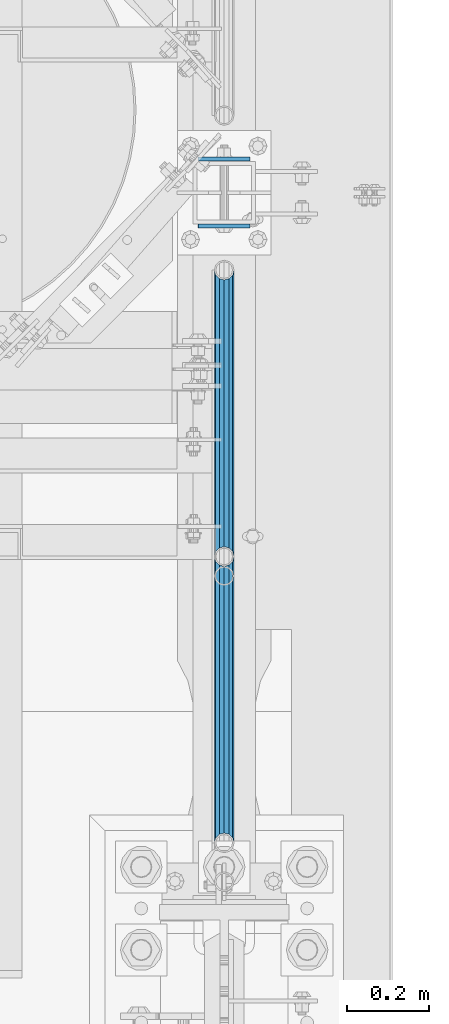
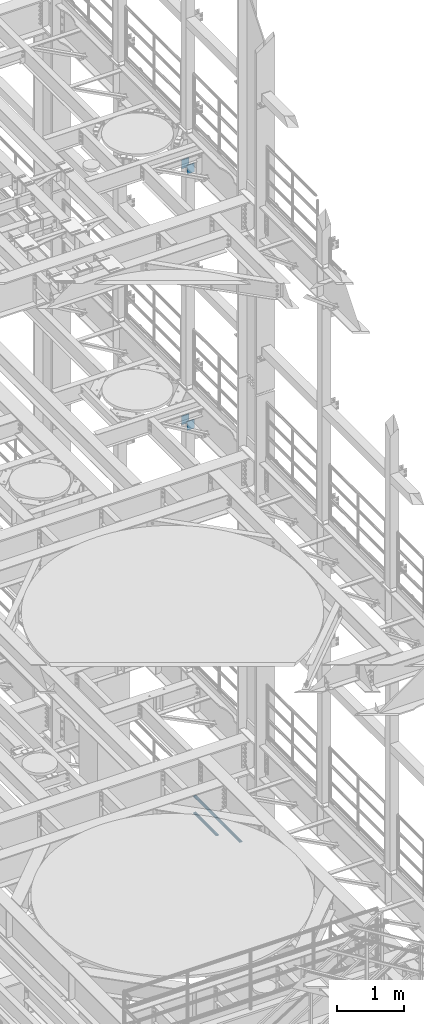
# One storey, part 1277 of 1876: 7 beams, 3 elements without a shape of their own.
"""IFC2X3 building model written with IfcOpenShell, lengths in millimetres."""

from ifc_helpers import new_model, si_unit, frame, origin_with_axes, place, context, subcontext, project, spatial, faceted_brep, material, type_object, element, aggregate, save


model = new_model("IFC2X3")

# Units and contexts
model_context = context("Model", 3, precision=1e-05, world=origin_with_axes())
body_context = subcontext(model_context, "Body", "Model", "MODEL_VIEW")
ifc_project = project(units=[si_unit("LENGTHUNIT", "METRE", prefix="MILLI"), si_unit("AREAUNIT", "SQUARE_METRE"), si_unit("VOLUMEUNIT", "CUBIC_METRE"), si_unit("MASSUNIT", "GRAM", prefix="KILO"), si_unit("TIMEUNIT", "SECOND"), si_unit("PLANEANGLEUNIT", "RADIAN"), si_unit("SOLIDANGLEUNIT", "STERADIAN"), si_unit("THERMODYNAMICTEMPERATUREUNIT", "DEGREE_CELSIUS"), si_unit("LUMINOUSINTENSITYUNIT", "LUMEN")], contexts=[model_context])

# Site, building, storey
site_placement = place(None, origin_with_axes())
site = spatial("IfcSite", under=ifc_project, at=site_placement, CompositionType="ELEMENT")
building_placement = place(site_placement, origin_with_axes())
building = spatial("IfcBuilding", under=site, at=building_placement, Name="Undefined", CompositionType="ELEMENT")
storey_placement = place(building_placement, origin_with_axes())
storey = spatial("IfcBuildingStorey", under=building, at=storey_placement, Name="Undefined", CompositionType="ELEMENT", Elevation=0.0)

# Assembly, beams
assembly_1_placement = place(storey_placement, origin_with_axes())
assembly_1 = element("IfcElementAssembly", 1, at=assembly_1_placement, inside=storey, Name="RAIL", AssemblyPlace="NOTDEFINED", PredefinedType="RIGID_FRAME")
ifc_material_1 = material()
beam_type_1 = type_object("IfcBeamType", Name="PIPE1-1/2SCH40", PredefinedType="NOTDEFINED")
beam_1_placement = place(assembly_1_placement, frame((7620.0, 2665.4125, 5597.525), z_axis=(0.0, 0.0, -1.0), x_axis=(0.0, 1.0, 0.0)))
beam_1 = element("IfcBeam", 2, at=beam_1_placement, type_object=beam_type_1, material=ifc_material_1, Name="RAIL", ObjectType="PIPE1-1/2SCH40", context=body_context, shape_type="Brep", body=[
    faceted_brep([(0.0, 24.1299999999992, 0.0), (12.0650000000064, 20.8971929933177, -12.0649999999987), (12.0650000000064, 20.8971929933177, 12.0649999999987), (12.0650000000064, -20.8971929933177, 12.0649999999987), (12.0650000000064, -20.8971929933177, -12.0649999999987), (0.0, -24.1299999999992, 0.0), (20.8971929933249, -12.0650000000005, 20.8971929933177), (20.8971929933249, -12.0650000000005, 15.8661214311796), (15.2545715621445, -17.7076214311801, 10.2235000000001), (12.5151929933249, -20.4470000000001, 0.0), (15.2545715621445, -17.7076214311801, -10.2235000000001), (20.8971929933249, -12.0650000000005, -15.8661214311796), (20.8971929933249, -12.0650000000005, -20.8971929933177), (24.1300000000063, 0.0, -20.4470000000001), (24.1300000000063, 0.0, -24.130000000001), (21.3906214311868, -10.2235000000001, -17.7076214311819), (21.3906214311868, 10.2235000000001, -17.7076214311819), (20.8971929933249, 12.0650000000005, -15.8661214311796), (20.8971929933249, 12.0650000000005, -20.8971929933177), (15.2545715621445, 17.7076214311801, -10.2235000000001), (12.5151929933249, 20.4470000000001, 0.0), (15.2545715621445, 17.7076214311801, 10.2235000000001), (20.8971929933249, 12.0650000000005, 15.8661214311796), (20.8971929933249, 12.0650000000005, 20.8971929933177), (21.3906214311868, 10.2235000000001, 17.7076214311819), (24.1300000000064, 0.0, 20.4470000000001), (24.1300000000064, 0.0, 24.130000000001), (21.3906214311868, -10.2235000000001, 17.7076214311819), (701.3575, 24.1300000000001, 0.0), (689.2925, 20.8971929933186, -12.0649999999996), (680.460307006681, 12.0649999999996, -20.8971929933186), (701.3575, -24.1299999999919, 0.0), (689.2925, -20.8971929933186, -12.0649999999996), (689.2925, -20.8971929933186, 12.0649999999996), (680.460307006681, -12.0649999999996, 20.8971929933186), (680.460307006681, -12.0649999999996, -20.8971929933186), (677.2275, 0.0, -24.1300000000001), (679.966878568817, 10.2235000000001, -17.7076214311801), (677.2275, 0.0, -20.4470000000001), (680.460307006681, 12.0650000000078, -15.8661214311724), (680.460307006681, -12.0649999999914, -15.8661214311887), (679.966878568822, -10.2235000000001, -17.7076214311801), (686.10292843787, -17.7076214311801, -10.2235000000001), (688.842307006689, -20.4470000000001, 0.0), (686.10292843787, -17.7076214311801, 10.2235000000001), (680.460307006681, -12.0649999999914, 15.8661214311887), (679.966878568822, -10.2235000000001, 17.7076214311801), (677.2275, 0.0, 20.4470000000001), (677.2275, 0.0, 24.1300000000001), (680.460307006681, 12.0649999999996, 20.8971929933186), (689.2925, 20.8971929933186, 12.0649999999996), (680.460307006681, 12.0650000000078, 15.8661214311724), (686.102928437854, 17.7076214311801, 10.2235000000001), (688.842307006673, 20.4470000000001, 0.0), (686.102928437854, 17.7076214311801, -10.2235000000001), (679.966878568817, 10.2235000000001, 17.7076214311801)], [[[0, 1, 2]], [[3, 4, 5]], [[6, 7, 8, 9, 10, 11, 12, 4, 3]], [[13, 14, 12, 11, 15]], [[16, 17, 18, 14, 13]], [[2, 1, 18, 17, 19, 20, 21, 22, 23]], [[23, 22, 24, 25, 26]], [[26, 25, 27, 7, 6]], [[1, 0, 28, 29]], [[18, 1, 29, 30]], [[31, 32, 33]], [[6, 3, 33, 34]], [[3, 5, 31, 33]], [[5, 4, 32, 31]], [[4, 12, 35, 32]], [[12, 14, 36, 35]], [[14, 18, 30, 36]], [[37, 38, 36, 30, 39]], [[40, 35, 36, 38, 41]], [[33, 32, 35, 40, 42, 43, 44, 45, 34]], [[34, 45, 46, 47, 48]], [[26, 6, 34, 48]], [[2, 23, 49, 50]], [[23, 26, 48, 49]], [[0, 2, 50, 28]], [[28, 50, 29]], [[49, 51, 52, 53, 54, 39, 30, 29, 50]], [[48, 47, 55, 51, 49]], [[25, 24, 55, 47]], [[55, 24, 22, 21, 52, 51]], [[21, 20, 53, 52]], [[20, 19, 54, 53]], [[19, 17, 16, 37, 39, 54]], [[16, 13, 38, 37]], [[13, 15, 41, 38]], [[41, 15, 11, 10, 42, 40]], [[10, 9, 43, 42]], [[9, 8, 44, 43]], [[8, 7, 27, 46, 45, 44]], [[27, 25, 47, 46]]]),
])
beam_2_placement = place(assembly_1_placement, frame((7620.0, 1964.055, 5902.325), z_axis=(0.0, 0.0, -1.0), x_axis=(0.0, 1.0, 0.0)))
beam_2 = element("IfcBeam", 3, at=beam_2_placement, type_object=beam_type_1, material=ifc_material_1, Name="RAIL", ObjectType="PIPE1-1/2SCH40", context=body_context, shape_type="Brep", body=[
    faceted_brep([(0.0, 24.1299999999992, 0.0), (12.0650000000064, 20.8971929933177, -12.0649999999987), (12.0650000000064, 20.8971929933177, 12.0649999999987), (12.0650000000064, -20.8971929933177, 12.0649999999987), (12.0650000000064, -20.8971929933177, -12.0649999999987), (0.0, -24.1299999999992, 0.0), (20.8971929933249, -12.0650000000005, 20.8971929933177), (20.8971929933249, -12.0650000000005, 15.8661214311796), (15.2545715621445, -17.7076214311801, 10.2235000000001), (12.5151929933249, -20.4470000000001, 0.0), (15.2545715621445, -17.7076214311801, -10.2235000000001), (20.8971929933249, -12.0650000000005, -15.8661214311796), (20.8971929933249, -12.0650000000005, -20.8971929933177), (24.1300000000063, 0.0, -20.4470000000001), (24.1300000000063, 0.0, -24.130000000001), (21.3906214311868, -10.2235000000001, -17.7076214311819), (21.3906214311868, 10.2235000000001, -17.7076214311819), (20.8971929933249, 12.0650000000005, -15.8661214311796), (20.8971929933249, 12.0650000000005, -20.8971929933177), (15.2545715621445, 17.7076214311801, -10.2235000000001), (12.5151929933249, 20.4470000000001, 0.0), (15.2545715621445, 17.7076214311801, 10.2235000000001), (20.8971929933249, 12.0650000000005, 15.8661214311796), (20.8971929933249, 12.0650000000005, 20.8971929933177), (21.3906214311868, 10.2235000000001, 17.7076214311819), (24.1300000000064, 0.0, 20.4470000000001), (24.1300000000064, 0.0, 24.130000000001), (21.3906214311868, -10.2235000000001, 17.7076214311819), (701.3575, 24.1300000000001, 0.0), (689.2925, 20.8971929933186, -12.0649999999996), (680.460307006681, 12.0649999999996, -20.8971929933186), (701.3575, -24.1299999999919, 0.0), (689.2925, -20.8971929933186, -12.0649999999996), (689.2925, -20.8971929933186, 12.0649999999996), (680.460307006681, -12.0649999999996, 20.8971929933186), (680.460307006681, -12.0649999999996, -20.8971929933186), (677.2275, 0.0, -24.1300000000001), (679.966878568817, 10.2235000000001, -17.7076214311801), (677.2275, 0.0, -20.4470000000001), (680.460307006681, 12.0650000000078, -15.8661214311724), (680.460307006681, -12.0649999999914, -15.8661214311887), (679.966878568822, -10.2235000000001, -17.7076214311801), (686.10292843787, -17.7076214311801, -10.2235000000001), (688.842307006689, -20.4470000000001, 0.0), (686.10292843787, -17.7076214311801, 10.2235000000001), (680.460307006681, -12.0649999999914, 15.8661214311887), (679.966878568822, -10.2235000000001, 17.7076214311801), (677.2275, 0.0, 20.4470000000001), (677.2275, 0.0, 24.1300000000001), (680.460307006681, 12.0649999999996, 20.8971929933186), (689.2925, 20.8971929933186, 12.0649999999996), (680.460307006681, 12.0650000000078, 15.8661214311724), (686.102928437854, 17.7076214311801, 10.2235000000001), (688.842307006673, 20.4470000000001, 0.0), (686.102928437854, 17.7076214311801, -10.2235000000001), (679.966878568817, 10.2235000000001, 17.7076214311801)], [[[0, 1, 2]], [[3, 4, 5]], [[6, 7, 8, 9, 10, 11, 12, 4, 3]], [[13, 14, 12, 11, 15]], [[16, 17, 18, 14, 13]], [[2, 1, 18, 17, 19, 20, 21, 22, 23]], [[23, 22, 24, 25, 26]], [[26, 25, 27, 7, 6]], [[1, 0, 28, 29]], [[18, 1, 29, 30]], [[31, 32, 33]], [[6, 3, 33, 34]], [[3, 5, 31, 33]], [[5, 4, 32, 31]], [[4, 12, 35, 32]], [[12, 14, 36, 35]], [[14, 18, 30, 36]], [[37, 38, 36, 30, 39]], [[40, 35, 36, 38, 41]], [[33, 32, 35, 40, 42, 43, 44, 45, 34]], [[34, 45, 46, 47, 48]], [[26, 6, 34, 48]], [[2, 23, 49, 50]], [[23, 26, 48, 49]], [[0, 2, 50, 28]], [[28, 50, 29]], [[49, 51, 52, 53, 54, 39, 30, 29, 50]], [[48, 47, 55, 51, 49]], [[25, 24, 55, 47]], [[55, 24, 22, 21, 52, 51]], [[21, 20, 53, 52]], [[20, 19, 54, 53]], [[19, 17, 16, 37, 39, 54]], [[16, 13, 38, 37]], [[13, 15, 41, 38]], [[41, 15, 11, 10, 42, 40]], [[10, 9, 43, 42]], [[9, 8, 44, 43]], [[8, 7, 27, 46, 45, 44]], [[27, 25, 47, 46]]]),
])
beam_3_placement = place(assembly_1_placement, frame((7620.0, 2665.4125, 5902.325), z_axis=(0.0, 0.0, -1.0), x_axis=(0.0, 1.0, 0.0)))
beam_3 = element("IfcBeam", 4, at=beam_3_placement, type_object=beam_type_1, material=ifc_material_1, Name="RAIL", ObjectType="PIPE1-1/2SCH40", context=body_context, shape_type="Brep", body=[
    faceted_brep([(0.0, 24.1299999999992, 0.0), (12.0650000000064, 20.8971929933177, -12.0649999999987), (12.0650000000064, 20.8971929933177, 12.0649999999987), (12.0650000000064, -20.8971929933177, 12.0649999999987), (12.0650000000064, -20.8971929933177, -12.0649999999987), (0.0, -24.1299999999992, 0.0), (20.8971929933249, -12.0650000000005, 20.8971929933177), (20.8971929933249, -12.0650000000005, 15.8661214311796), (15.2545715621445, -17.7076214311801, 10.2235000000001), (12.5151929933249, -20.4470000000001, 0.0), (15.2545715621445, -17.7076214311801, -10.2235000000001), (20.8971929933249, -12.0650000000005, -15.8661214311796), (20.8971929933249, -12.0650000000005, -20.8971929933177), (24.1300000000063, 0.0, -20.4470000000001), (24.1300000000063, 0.0, -24.130000000001), (21.3906214311868, -10.2235000000001, -17.7076214311819), (21.3906214311868, 10.2235000000001, -17.7076214311819), (20.8971929933249, 12.0650000000005, -15.8661214311796), (20.8971929933249, 12.0650000000005, -20.8971929933177), (15.2545715621445, 17.7076214311801, -10.2235000000001), (12.5151929933249, 20.4470000000001, 0.0), (15.2545715621445, 17.7076214311801, 10.2235000000001), (20.8971929933249, 12.0650000000005, 15.8661214311796), (20.8971929933249, 12.0650000000005, 20.8971929933177), (21.3906214311868, 10.2235000000001, 17.7076214311819), (24.1300000000064, 0.0, 20.4470000000001), (24.1300000000064, 0.0, 24.130000000001), (21.3906214311868, -10.2235000000001, 17.7076214311819), (701.3575, 24.1300000000001, 0.0), (689.2925, 20.8971929933186, -12.0649999999996), (680.460307006681, 12.0649999999996, -20.8971929933186), (701.3575, -24.1299999999919, 0.0), (689.2925, -20.8971929933186, -12.0649999999996), (689.2925, -20.8971929933186, 12.0649999999996), (680.460307006681, -12.0649999999996, 20.8971929933186), (680.460307006681, -12.0649999999996, -20.8971929933186), (677.2275, 0.0, -24.1300000000001), (679.966878568817, 10.2235000000001, -17.7076214311801), (677.2275, 0.0, -20.4470000000001), (680.460307006681, 12.0650000000078, -15.8661214311724), (680.460307006681, -12.0649999999914, -15.8661214311887), (679.966878568822, -10.2235000000001, -17.7076214311801), (686.10292843787, -17.7076214311801, -10.2235000000001), (688.842307006689, -20.4470000000001, 0.0), (686.10292843787, -17.7076214311801, 10.2235000000001), (680.460307006681, -12.0649999999914, 15.8661214311887), (679.966878568822, -10.2235000000001, 17.7076214311801), (677.2275, 0.0, 20.4470000000001), (677.2275, 0.0, 24.1300000000001), (680.460307006681, 12.0649999999996, 20.8971929933186), (689.2925, 20.8971929933186, 12.0649999999996), (680.460307006681, 12.0650000000078, 15.8661214311724), (686.102928437854, 17.7076214311801, 10.2235000000001), (688.842307006673, 20.4470000000001, 0.0), (686.102928437854, 17.7076214311801, -10.2235000000001), (679.966878568817, 10.2235000000001, 17.7076214311801)], [[[0, 1, 2]], [[3, 4, 5]], [[6, 7, 8, 9, 10, 11, 12, 4, 3]], [[13, 14, 12, 11, 15]], [[16, 17, 18, 14, 13]], [[2, 1, 18, 17, 19, 20, 21, 22, 23]], [[23, 22, 24, 25, 26]], [[26, 25, 27, 7, 6]], [[1, 0, 28, 29]], [[18, 1, 29, 30]], [[31, 32, 33]], [[6, 3, 33, 34]], [[3, 5, 31, 33]], [[5, 4, 32, 31]], [[4, 12, 35, 32]], [[12, 14, 36, 35]], [[14, 18, 30, 36]], [[37, 38, 36, 30, 39]], [[40, 35, 36, 38, 41]], [[33, 32, 35, 40, 42, 43, 44, 45, 34]], [[34, 45, 46, 47, 48]], [[26, 6, 34, 48]], [[2, 23, 49, 50]], [[23, 26, 48, 49]], [[0, 2, 50, 28]], [[28, 50, 29]], [[49, 51, 52, 53, 54, 39, 30, 29, 50]], [[48, 47, 55, 51, 49]], [[25, 24, 55, 47]], [[55, 24, 22, 21, 52, 51]], [[21, 20, 53, 52]], [[20, 19, 54, 53]], [[19, 17, 16, 37, 39, 54]], [[16, 13, 38, 37]], [[13, 15, 41, 38]], [[41, 15, 11, 10, 42, 40]], [[10, 9, 43, 42]], [[9, 8, 44, 43]], [[8, 7, 27, 46, 45, 44]], [[27, 25, 47, 46]]]),
])
aggregate(assembly_1, [beam_1, beam_2, beam_3])

assembly_2_placement = place(storey_placement, origin_with_axes())
assembly_2 = element("IfcElementAssembly", 5, at=assembly_2_placement, inside=storey, Name="BEAM", AssemblyPlace="NOTDEFINED", PredefinedType="RIGID_FRAME")
ifc_material_2 = material(Name="STEEL/A36")
beam_type_2 = type_object("IfcBeamType", PredefinedType="NOTDEFINED")
beam_4_placement = place(assembly_2_placement, frame((7556.36848042001, 3638.55, 12604.7488224823), z_axis=(2.95459999824743e-05, 0.0, -0.999999999563517), x_axis=(0.999999999563517, 0.0, 2.95459999828704e-05)))
beam_4 = element("IfcBeam", 6, at=beam_4_placement, type_object=beam_type_2, material=ifc_material_2, Name="PLATE", context=body_context, shape_type="Brep", body=[
    faceted_brep([(0.0, 4.76249999999982, -82.5499999999993), (0.0, 4.76249999999982, 82.5499999999993), (127.0, 4.76249999999982, 82.5499999999993), (127.0, 4.76249999999982, -82.5499999999993), (0.0, -4.76249999999982, 82.5499999999993), (127.0, -4.76249999999982, 82.5499999999993), (0.0, -4.76249999999982, -82.5499999999993), (127.0, -4.76249999999982, -82.5499999999993)], [[[0, 1, 2, 3]], [[1, 4, 5, 2]], [[4, 6, 7, 5]], [[6, 0, 3, 7]], [[5, 7, 3, 2]], [[6, 4, 1, 0]]]),
])
beam_5_placement = place(assembly_2_placement, frame((7556.36848042001, 3475.0375, 12604.7488224823), z_axis=(2.95459999824743e-05, 0.0, -0.999999999563517), x_axis=(0.999999999563517, 0.0, 2.95459999828704e-05)))
beam_5 = element("IfcBeam", 7, at=beam_5_placement, type_object=beam_type_2, material=ifc_material_2, Name="PLATE", context=body_context, shape_type="Brep", body=[
    faceted_brep([(0.0, 4.76249999999982, -82.5499999999993), (0.0, 4.76249999999982, 82.5499999999993), (127.0, 4.76249999999982, 82.5499999999993), (127.0, 4.76249999999982, -82.5499999999993), (0.0, -4.76249999999982, 82.5499999999993), (127.0, -4.76249999999982, 82.5499999999993), (0.0, -4.76249999999982, -82.5499999999993), (127.0, -4.76249999999982, -82.5499999999993)], [[[0, 1, 2, 3]], [[1, 4, 5, 2]], [[4, 6, 7, 5]], [[6, 0, 3, 7]], [[5, 7, 3, 2]], [[6, 4, 1, 0]]]),
])
aggregate(assembly_2, [beam_4, beam_5])

assembly_3_placement = place(storey_placement, origin_with_axes())
assembly_3 = element("IfcElementAssembly", 8, at=assembly_3_placement, inside=storey, Name="BEAM", AssemblyPlace="NOTDEFINED", PredefinedType="RIGID_FRAME")
beam_6_placement = place(assembly_3_placement, frame((7556.5, 3638.55, 17278.35), z_axis=(0.0, 0.0, -1.0), x_axis=(1.0, 0.0, 0.0)))
beam_6 = element("IfcBeam", 9, at=beam_6_placement, type_object=beam_type_2, material=ifc_material_2, Name="PLATE", context=body_context, shape_type="Brep", body=[
    faceted_brep([(0.0, 4.76249999999982, -82.5499999999993), (0.0, 4.76249999999982, 82.5499999999993), (127.0, 4.76249999999982, 82.5499999999993), (127.0, 4.76249999999982, -82.5499999999993), (0.0, -4.76249999999982, 82.5499999999993), (127.0, -4.76249999999982, 82.5499999999993), (0.0, -4.76249999999982, -82.5499999999993), (127.0, -4.76249999999982, -82.5499999999993)], [[[0, 1, 2, 3]], [[1, 4, 5, 2]], [[4, 6, 7, 5]], [[6, 0, 3, 7]], [[5, 7, 3, 2]], [[6, 4, 1, 0]]]),
])
beam_7_placement = place(assembly_3_placement, frame((7556.5, 3475.0375, 17278.35), z_axis=(0.0, 0.0, -1.0), x_axis=(1.0, 0.0, 0.0)))
beam_7 = element("IfcBeam", 10, at=beam_7_placement, type_object=beam_type_2, material=ifc_material_2, Name="PLATE", context=body_context, shape_type="Brep", body=[
    faceted_brep([(0.0, 4.76249999999982, -82.5499999999993), (0.0, 4.76249999999982, 82.5499999999993), (127.0, 4.76249999999982, 82.5499999999993), (127.0, 4.76249999999982, -82.5499999999993), (0.0, -4.76249999999982, 82.5499999999993), (127.0, -4.76249999999982, 82.5499999999993), (0.0, -4.76249999999982, -82.5499999999993), (127.0, -4.76249999999982, -82.5499999999993)], [[[0, 1, 2, 3]], [[1, 4, 5, 2]], [[4, 6, 7, 5]], [[6, 0, 3, 7]], [[5, 7, 3, 2]], [[6, 4, 1, 0]]]),
])
aggregate(assembly_3, [beam_6, beam_7])

save(model, "model.ifc")
